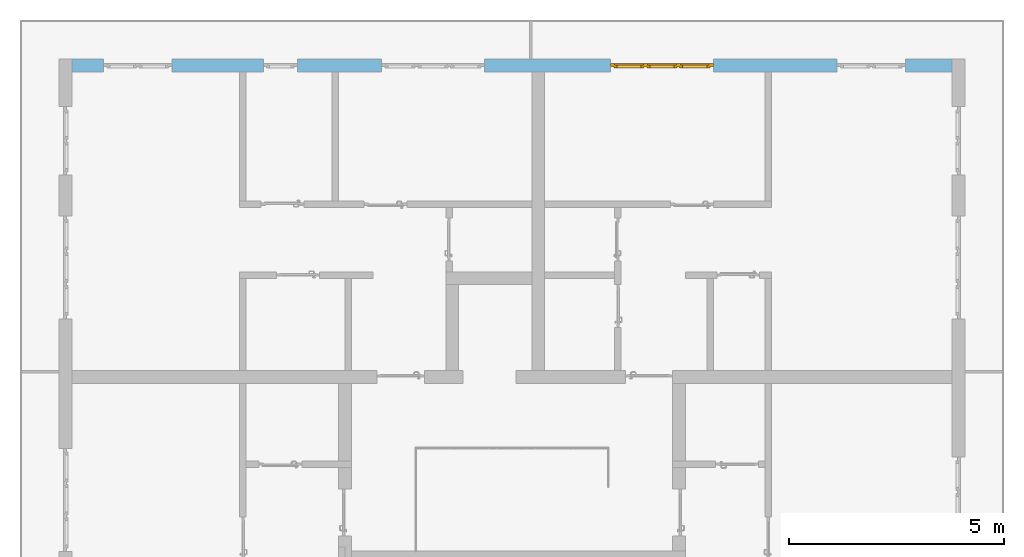
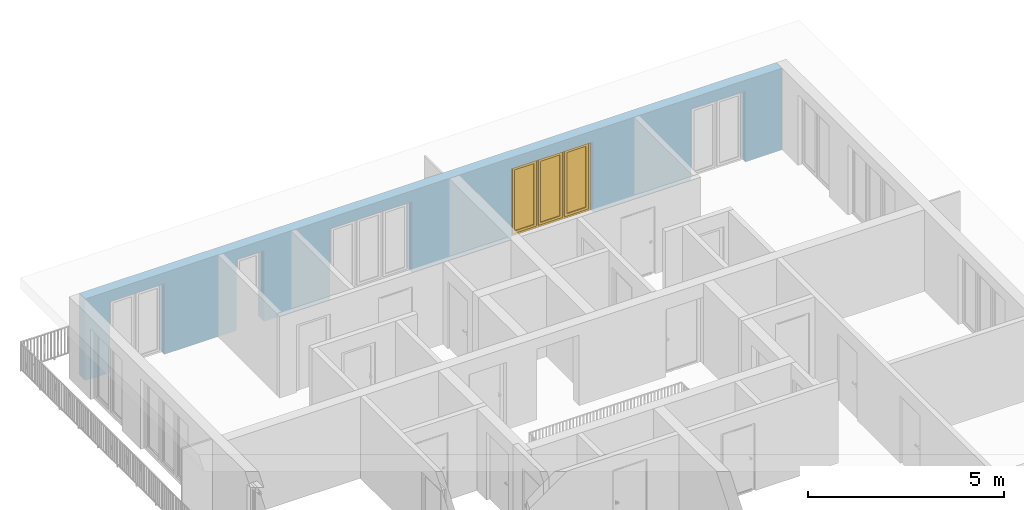
# One storey, part 29 of 54: 1 window, 5 openings, plus 1 element that does not belong to this part.
"""IFC4 building model written with IfcOpenShell, lengths in metres."""

from ifc_helpers import new_model, entity, si_unit, converted_unit, derived_unit, direction, frame, origin_with_axes, place, context, subcontext, project, spatial, polygons, source, transform, mapped, material, type_object, element, fill, save


model = new_model("IFC4")

# Units and contexts
model_context = context("Model", 3, precision=1e-05, world=origin_with_axes(), true_north=direction((0.0, 1.0)))
body_context = subcontext(model_context, "Body", "Model", "MODEL_VIEW")
ifc_project = project(units=[si_unit("LENGTHUNIT", "METRE"), si_unit("AREAUNIT", "SQUARE_METRE"), si_unit("VOLUMEUNIT", "CUBIC_METRE"), converted_unit("PLANEANGLEUNIT", "DEGREE", entity("IfcPlaneAngleMeasure", 0.0174532925199), si_unit("PLANEANGLEUNIT", "RADIAN"), dimensions=[0, 0, 0, 0, 0, 0, 0]), converted_unit("TIMEUNIT", "Year", entity("IfcTimeMeasure", 31556926.0), si_unit("TIMEUNIT", "SECOND"), dimensions=[0, 0, 1, 0, 0, 0, 0]), si_unit("MASSUNIT", "GRAM", prefix="KILO"), si_unit("THERMODYNAMICTEMPERATUREUNIT", "DEGREE_CELSIUS"), si_unit("LUMINOUSINTENSITYUNIT", "LUMEN"), si_unit("ENERGYUNIT", "JOULE", prefix="MEGA"), derived_unit("THERMALCONDUCTANCEUNIT", [(si_unit("POWERUNIT", "WATT"), 1), (si_unit("LENGTHUNIT", "METRE"), -1), (si_unit("THERMODYNAMICTEMPERATUREUNIT", "KELVIN"), -1)]), derived_unit("SPECIFICHEATCAPACITYUNIT", [(si_unit("ENERGYUNIT", "JOULE"), 1), (si_unit("MASSUNIT", "GRAM", prefix="KILO"), -1), (si_unit("THERMODYNAMICTEMPERATUREUNIT", "KELVIN"), -1)]), derived_unit("MASSDENSITYUNIT", [(si_unit("MASSUNIT", "GRAM", prefix="KILO"), 1), (si_unit("VOLUMEUNIT", "CUBIC_METRE"), -1)])], contexts=[model_context])

# Site, building, storey
site_placement = place(None, origin_with_axes())
site = spatial("IfcSite", under=ifc_project, at=site_placement, CompositionType="ELEMENT")
building_placement = place(site_placement, origin_with_axes())
building = spatial("IfcBuilding", under=site, at=building_placement, CompositionType="ELEMENT")
storey_placement = place(building_placement, frame((0.0, 0.0, 9.18), z_axis=(0.0, 0.0, 1.0), x_axis=(1.0, 0.0, 0.0)))
storey = spatial("IfcBuildingStorey", under=building, at=storey_placement, Name="3. Geschoss", CompositionType="ELEMENT", Elevation=9.18)

# Wall, openings, window
ifc_material = material()
wall_type = type_object("IfcWallType", Name="300", PredefinedType="NOTDEFINED")
wall_placement = place(storey_placement, frame((-11.7421993804, 8.92118776896, 0.0), z_axis=(0.0, 0.0, 1.0), x_axis=(1.0, 0.0, 0.0)))
wall = element("IfcWall", 1, at=wall_placement, inside=storey, type_object=wall_type, material=ifc_material, Name="Wand-001", PredefinedType="NOTDEFINED", context=body_context, shape_type="Tessellation", body=[
    polygons([(15.23, -0.1, 0.0), (15.23, -0.3, 0.0), (15.23, -0.3, 2.2), (15.23, 0.0, 2.2), (15.23, 0.0, 0.0), (18.102139809, 0.0, 0.0), (18.102139809, -0.3, 0.0), (18.102139809, -0.3, 2.2), (19.702139809, -0.3, 2.2), (19.702139809, -0.3, 0.0), (20.78, -0.3, 0.0), (20.78, -0.3, 2.54), (0.3, -0.3, 2.54), (0.3, -0.3, 0.0), (1.0288518641, -0.3, 0.0), (1.0288518641, -0.3, 2.2), (2.6288518641, -0.3, 2.2), (2.6288518641, -0.3, 0.0), (4.75, -0.3, 0.0), (4.75, -0.3, 2.2), (5.55, -0.3, 2.2), (5.55, -0.3, 0.0), (7.50089858046, -0.3, 0.0), (7.50089858046, -0.3, 2.2), (9.90089858046, -0.3, 2.2), (9.90089858046, -0.3, 0.0), (12.83, -0.3, 0.0), (12.83, -0.3, 2.2), (12.83, 0.0, 2.2), (12.83, 0.0, 0.0), (9.90089858046, 0.0, 0.0), (9.90089858046, 0.0, 2.2), (7.50089858046, 0.0, 2.2), (7.50089858046, 0.0, 0.0), (5.55, 0.0, 0.0), (5.55, 0.0, 2.2), (4.75, 0.0, 2.2), (4.75, 0.0, 0.0), (2.6288518641, 0.0, 0.0), (2.6288518641, 0.0, 2.2), (1.0288518641, 0.0, 2.2), (1.0288518641, 0.0, 0.0), (0.3, 0.0, 0.0), (0.3, 0.0, 2.54), (20.78, 0.0, 2.54), (20.78, 0.0, 0.0), (19.702139809, 0.0, 0.0), (19.702139809, 0.0, 2.2), (18.102139809, 0.0, 2.2), (12.83, -0.1, 0.0)], [[[1, 2, 3, 4, 5]], [[2, 1, 5, 6, 7]], [[3, 2, 7, 8, 9, 10, 11, 12, 13, 14, 15, 16, 17, 18, 19, 20, 21, 22, 23, 24, 25, 26, 27, 28]], [[4, 3, 28, 29]], [[6, 5, 4, 29, 30, 31, 32, 33, 34, 35, 36, 37, 38, 39, 40, 41, 42, 43, 44, 45, 46, 47, 48, 49]], [[6, 49, 8, 7]], [[8, 49, 48, 9]], [[48, 47, 10, 9]], [[46, 11, 10, 47]], [[12, 11, 46, 45]], [[45, 44, 13, 12]], [[44, 43, 14, 13]], [[15, 14, 43, 42]], [[16, 15, 42, 41]], [[40, 17, 16, 41]], [[18, 17, 40, 39]], [[19, 18, 39, 38]], [[20, 19, 38, 37]], [[36, 21, 20, 37]], [[22, 21, 36, 35]], [[22, 35, 34, 23]], [[34, 33, 24, 23]], [[24, 33, 32, 25]], [[32, 31, 26, 25]], [[50, 27, 26, 31, 30]], [[28, 27, 50, 30, 29]]], closed=True),
])
opening_1_placement = place(wall_placement, frame((1.8288518641, 0.0, 0.0), z_axis=(0.0, 0.0, 1.0), x_axis=(1.0, 0.0, 0.0)))
element("IfcOpeningElement", 2, at=opening_1_placement, cuts=wall, Name="Fenster-001", context=body_context, identifier="Reference", shape_type="Tessellation", body=[
    polygons([(-0.8, -0.1, 0.0), (-0.8, -0.1, 2.2), (-0.8, 0.000999999999998, 2.2), (-0.8, 0.000999999999998, 0.0), (-0.8, -0.301, 0.0), (-0.8, -0.301, 2.2), (0.8, -0.1, 2.2), (0.8, 0.000999999999999, 2.2), (0.8, -0.301, 2.2), (0.8, 0.000999999999999, 0.0), (0.8, -0.1, 0.0), (0.8, -0.301, 0.0)], [[[1, 2, 3, 4]], [[2, 1, 5, 6]], [[7, 8, 3, 2, 6, 9]], [[8, 10, 4, 3]], [[1, 4, 10, 11, 12, 5]], [[6, 5, 12, 9]], [[7, 11, 10, 8]], [[11, 7, 9, 12]]], closed=True),
])
opening_2_placement = place(wall_placement, frame((8.70089858046, 0.0, 0.0), z_axis=(0.0, 0.0, 1.0), x_axis=(1.0, 0.0, 0.0)))
element("IfcOpeningElement", 3, at=opening_2_placement, cuts=wall, Name="Fenster-002", context=body_context, identifier="Reference", shape_type="Tessellation", body=[
    polygons([(-1.2, -0.1, 0.0), (-1.2, -0.1, 2.2), (-1.2, 0.000999999999999, 2.2), (-1.2, 0.000999999999999, 0.0), (-1.2, -0.301, 0.0), (-1.2, -0.301, 2.2), (1.2, -0.1, 2.2), (1.2, 0.001, 2.2), (1.2, -0.301, 2.2), (1.2, 0.001, 0.0), (1.2, -0.1, 0.0), (1.2, -0.301, 0.0)], [[[1, 2, 3, 4]], [[2, 1, 5, 6]], [[7, 8, 3, 2, 6, 9]], [[8, 10, 4, 3]], [[1, 4, 10, 11, 12, 5]], [[6, 5, 12, 9]], [[7, 11, 10, 8]], [[11, 7, 9, 12]]], closed=True),
])
opening_3_placement = place(wall_placement, frame((5.15, 0.0, 0.0), z_axis=(0.0, 0.0, 1.0), x_axis=(1.0, 0.0, 0.0)))
element("IfcOpeningElement", 4, at=opening_3_placement, cuts=wall, Name="Fenster-003", context=body_context, identifier="Reference", shape_type="Tessellation", body=[
    polygons([(-0.4, -0.1, 0.0), (-0.4, -0.1, 2.2), (-0.4, 0.001, 2.2), (-0.4, 0.001, 0.0), (-0.4, -0.301, 0.0), (-0.4, -0.301, 2.2), (0.4, -0.1, 2.2), (0.4, 0.001, 2.2), (0.4, -0.301, 2.2), (0.4, 0.001, 0.0), (0.4, -0.1, 0.0), (0.4, -0.301, 0.0)], [[[1, 2, 3, 4]], [[2, 1, 5, 6]], [[7, 8, 3, 2, 6, 9]], [[8, 10, 4, 3]], [[1, 4, 10, 11, 12, 5]], [[6, 5, 12, 9]], [[7, 11, 10, 8]], [[11, 7, 9, 12]]], closed=True),
])
opening_4_placement = place(wall_placement, frame((18.902139809, 0.0, 0.0), z_axis=(0.0, 0.0, 1.0), x_axis=(1.0, 0.0, 0.0)))
element("IfcOpeningElement", 5, at=opening_4_placement, cuts=wall, Name="Fenster-001", context=body_context, identifier="Reference", shape_type="Tessellation", body=[
    polygons([(-0.8, -0.1, 0.0), (-0.8, -0.1, 2.2), (-0.8, 0.001, 2.2), (-0.8, 0.001, 0.0), (-0.8, -0.301, 0.0), (-0.8, -0.301, 2.2), (0.8, -0.1, 2.2), (0.8, 0.001, 2.2), (0.8, -0.301, 2.2), (0.8, 0.001, 0.0), (0.8, -0.1, 0.0), (0.8, -0.301, 0.0)], [[[1, 2, 3, 4]], [[2, 1, 5, 6]], [[7, 8, 3, 2, 6, 9]], [[8, 10, 4, 3]], [[1, 4, 10, 11, 12, 5]], [[6, 5, 12, 9]], [[7, 11, 10, 8]], [[11, 7, 9, 12]]], closed=True),
])
opening_5_placement = place(wall_placement, frame((14.03, 0.0, 0.0), z_axis=(0.0, 0.0, 1.0), x_axis=(1.0, 0.0, 0.0)))
opening_5 = element("IfcOpeningElement", 6, at=opening_5_placement, cuts=wall, Name="Fenster-002", context=body_context, identifier="Reference", shape_type="Tessellation", body=[
    polygons([(-1.2, -0.1, 0.0), (-1.2, -0.1, 2.2), (-1.2, 0.001, 2.2), (-1.2, 0.001, 0.0), (-1.2, -0.301, 0.0), (-1.2, -0.301, 2.2), (1.2, -0.1, 2.2), (1.2, 0.001, 2.2), (1.2, -0.301, 2.2), (1.2, 0.001, 0.0), (1.2, -0.1, 0.0), (1.2, -0.301, 0.0)], [[[1, 2, 3, 4]], [[2, 1, 5, 6]], [[7, 8, 3, 2, 6, 9]], [[8, 10, 4, 3]], [[1, 4, 10, 11, 12, 5]], [[6, 5, 12, 9]], [[7, 11, 10, 8]], [[11, 7, 9, 12]]], closed=True),
])
window_type = type_object("IfcWindowType", Name="3-1+1+1 26", PartitioningType="TRIPLE_PANEL_VERTICAL", PredefinedType="WINDOW")
shared_shape = source(origin_with_axes(), body_context, "Body", "Tessellation", [
    polygons([(-1.2, -0.07, 0.0), (-1.2, 0.0, 0.0), (-1.1, 0.0, 0.1), (-1.1, -0.07, 0.1), (-1.2, -0.07, 2.2), (-1.2, 0.0, 2.2), (-1.1, 0.0, 2.1), (-1.1, -0.07, 2.1)], [[[1, 2, 3, 4]], [[5, 6, 2, 1]], [[2, 6, 7, 3]], [[4, 3, 7, 8]], [[1, 4, 8, 5]], [[8, 7, 6, 5]]], closed=True),
    polygons([(1.2, -0.07, 0.0), (1.2, 0.0, 0.0), (1.2, 0.0, 2.2), (1.2, -0.07, 2.2), (1.1, -0.07, 0.1), (1.1, 0.0, 0.1), (1.1, 0.0, 2.1), (1.1, -0.07, 2.1)], [[[1, 2, 3, 4]], [[5, 6, 2, 1]], [[2, 6, 7, 3]], [[4, 3, 7, 8]], [[1, 4, 8, 5]], [[8, 7, 6, 5]]], closed=True),
    polygons([(-1.2, -0.07, 0.0), (-1.2, 0.0, 0.0), (1.2, 0.0, 0.0), (1.2, -0.07, 0.0), (-1.1, -0.07, 0.1), (-1.1, 0.0, 0.1), (-0.433333333333, 0.0, 0.1), (-0.333333333333, 0.0, 0.1), (0.333333333333, 0.0, 0.1), (0.433333333333, 0.0, 0.1), (1.1, 0.0, 0.1), (1.1, -0.07, 0.1), (0.433333333333, -0.07, 0.1), (0.333333333333, -0.07, 0.1), (-0.333333333333, -0.07, 0.1), (-0.433333333333, -0.07, 0.1)], [[[1, 2, 3, 4]], [[5, 6, 2, 1]], [[2, 6, 7, 8, 9, 10, 11, 3]], [[4, 3, 11, 12]], [[1, 4, 12, 13, 14, 15, 16, 5]], [[16, 7, 6, 5]], [[15, 8, 7, 16]], [[14, 9, 8, 15]], [[13, 10, 9, 14]], [[12, 11, 10, 13]]], closed=True),
    polygons([(-1.2, -0.07, 2.2), (-1.2, 0.0, 2.2), (-1.1, 0.0, 2.1), (-1.1, -0.07, 2.1), (1.2, -0.07, 2.2), (1.2, 0.0, 2.2), (1.1, 0.0, 2.1), (0.433333333333, 0.0, 2.1), (0.333333333333, 0.0, 2.1), (-0.333333333333, 0.0, 2.1), (-0.433333333333, 0.0, 2.1), (-0.433333333333, -0.07, 2.1), (-0.333333333333, -0.07, 2.1), (0.333333333333, -0.07, 2.1), (0.433333333333, -0.07, 2.1), (1.1, -0.07, 2.1)], [[[1, 2, 3, 4]], [[5, 6, 2, 1]], [[2, 6, 7, 8, 9, 10, 11, 3]], [[4, 3, 11, 12]], [[1, 4, 12, 13, 14, 15, 16, 5]], [[16, 7, 6, 5]], [[15, 8, 7, 16]], [[14, 9, 8, 15]], [[13, 10, 9, 14]], [[12, 11, 10, 13]]], closed=True),
    polygons([(0.333333333333, -0.07, 0.1), (0.333333333333, 0.0, 0.1), (0.433333333333, 0.0, 0.1), (0.433333333333, -0.07, 0.1), (0.333333333333, -0.07, 2.1), (0.333333333333, 0.0, 2.1), (0.433333333333, 0.0, 2.1), (0.433333333333, -0.07, 2.1)], [[[1, 2, 3, 4]], [[5, 6, 2, 1]], [[2, 6, 7, 3]], [[4, 3, 7, 8]], [[1, 4, 8, 5]], [[8, 7, 6, 5]]], closed=True),
    polygons([(-0.433333333333, -0.07, 0.1), (-0.433333333333, 0.0, 0.1), (-0.333333333333, 0.0, 0.1), (-0.333333333333, -0.07, 0.1), (-0.433333333333, -0.07, 2.1), (-0.433333333333, 0.0, 2.1), (-0.333333333333, 0.0, 2.1), (-0.333333333333, -0.07, 2.1)], [[[1, 2, 3, 4]], [[5, 6, 2, 1]], [[2, 6, 7, 3]], [[4, 3, 7, 8]], [[1, 4, 8, 5]], [[8, 7, 6, 5]]], closed=True),
    polygons([(-1.12, 0.0, 0.08), (-1.12, 0.03, 0.08), (-1.05, 0.03, 0.15), (-1.05, 0.0, 0.15), (-1.12, 0.0, 2.12), (-1.12, 0.03, 2.12), (-1.05, 0.03, 2.05), (-1.05, 0.0, 2.05)], [[[1, 2, 3, 4]], [[5, 6, 2, 1]], [[2, 6, 7, 3]], [[4, 3, 7, 8]], [[1, 4, 8, 5]], [[8, 7, 6, 5]]], closed=True),
    polygons([(-0.413333333333, 0.0, 0.08), (-0.483333333333, 0.0, 0.15), (-0.483333333333, 0.03, 0.15), (-0.413333333333, 0.03, 0.08), (-0.413333333333, 0.0, 2.12), (-0.483333333333, 0.0, 2.05), (-0.483333333333, 0.03, 2.05), (-0.413333333333, 0.03, 2.12)], [[[1, 2, 3, 4]], [[1, 5, 6, 2]], [[2, 6, 7, 3]], [[4, 3, 7, 8]], [[5, 1, 4, 8]], [[6, 5, 8, 7]]], closed=True),
    polygons([(-1.12, 0.0, 0.08), (-1.12, 0.03, 0.08), (-0.413333333333, 0.03, 0.08), (-0.413333333333, 0.0, 0.08), (-1.05, 0.0, 0.15), (-1.05, 0.03, 0.15), (-0.483333333333, 0.03, 0.15), (-0.483333333333, 0.0, 0.15)], [[[1, 2, 3, 4]], [[5, 6, 2, 1]], [[2, 6, 7, 3]], [[4, 3, 7, 8]], [[1, 4, 8, 5]], [[8, 7, 6, 5]]], closed=True),
    polygons([(-1.12, 0.0, 2.12), (-0.413333333333, 0.0, 2.12), (-0.413333333333, 0.03, 2.12), (-1.12, 0.03, 2.12), (-1.05, 0.0, 2.05), (-0.483333333333, 0.0, 2.05), (-0.483333333333, 0.03, 2.05), (-1.05, 0.03, 2.05)], [[[1, 2, 3, 4]], [[1, 5, 6, 2]], [[2, 6, 7, 3]], [[4, 3, 7, 8]], [[5, 1, 4, 8]], [[6, 5, 8, 7]]], closed=True),
    polygons([(-1.1, -0.03, 0.1), (-1.1, 0.0, 0.1), (-1.05, 0.0, 0.15), (-1.05, -0.03, 0.15), (-1.1, -0.03, 2.1), (-1.1, 0.0, 2.1), (-1.05, 0.0, 2.05), (-1.05, -0.03, 2.05)], [[[1, 2, 3, 4]], [[5, 6, 2, 1]], [[2, 6, 7, 3]], [[4, 3, 7, 8]], [[1, 4, 8, 5]], [[8, 7, 6, 5]]], closed=True),
    polygons([(-0.433333333333, -0.03, 0.1), (-0.483333333333, -0.03, 0.15), (-0.483333333333, 0.0, 0.15), (-0.433333333333, 0.0, 0.1), (-0.433333333333, -0.03, 2.1), (-0.483333333333, -0.03, 2.05), (-0.483333333333, 0.0, 2.05), (-0.433333333333, 0.0, 2.1)], [[[1, 2, 3, 4]], [[1, 5, 6, 2]], [[2, 6, 7, 3]], [[4, 3, 7, 8]], [[5, 1, 4, 8]], [[6, 5, 8, 7]]], closed=True),
    polygons([(-1.1, -0.03, 0.1), (-1.1, 0.0, 0.1), (-0.433333333333, 0.0, 0.1), (-0.433333333333, -0.03, 0.1), (-1.05, -0.03, 0.15), (-1.05, 0.0, 0.15), (-0.483333333333, 0.0, 0.15), (-0.483333333333, -0.03, 0.15)], [[[1, 2, 3, 4]], [[5, 6, 2, 1]], [[2, 6, 7, 3]], [[4, 3, 7, 8]], [[1, 4, 8, 5]], [[8, 7, 6, 5]]], closed=True),
    polygons([(-1.1, -0.03, 2.1), (-0.433333333333, -0.03, 2.1), (-0.433333333333, 0.0, 2.1), (-1.1, 0.0, 2.1), (-1.05, -0.03, 2.05), (-0.483333333333, -0.03, 2.05), (-0.483333333333, 0.0, 2.05), (-1.05, 0.0, 2.05)], [[[1, 2, 3, 4]], [[1, 5, 6, 2]], [[2, 6, 7, 3]], [[4, 3, 7, 8]], [[5, 1, 4, 8]], [[6, 5, 8, 7]]], closed=True),
    polygons([(-1.05, -0.005, 0.15), (-1.05, 0.005, 0.15), (-0.483333333333, 0.005, 0.15), (-0.483333333333, -0.005, 0.15), (-1.05, -0.005, 2.05), (-1.05, 0.005, 2.05), (-0.483333333333, 0.005, 2.05), (-0.483333333333, -0.005, 2.05)], [[[1, 2, 3, 4]], [[5, 6, 2, 1]], [[2, 6, 7, 3]], [[4, 3, 7, 8]], [[1, 4, 8, 5]], [[8, 7, 6, 5]]], closed=True),
    polygons([(-0.353333333333, 0.0, 0.08), (-0.353333333333, 0.03, 0.08), (-0.283333333333, 0.03, 0.15), (-0.283333333333, 0.0, 0.15), (-0.353333333333, 0.0, 2.12), (-0.353333333333, 0.03, 2.12), (-0.283333333333, 0.03, 2.05), (-0.283333333333, 0.0, 2.05)], [[[1, 2, 3, 4]], [[5, 6, 2, 1]], [[2, 6, 7, 3]], [[4, 3, 7, 8]], [[1, 4, 8, 5]], [[8, 7, 6, 5]]], closed=True),
    polygons([(0.353333333333, 0.0, 0.08), (0.283333333333, 0.0, 0.15), (0.283333333333, 0.03, 0.15), (0.353333333333, 0.03, 0.08), (0.353333333333, 0.0, 2.12), (0.283333333333, 0.0, 2.05), (0.283333333333, 0.03, 2.05), (0.353333333333, 0.03, 2.12)], [[[1, 2, 3, 4]], [[1, 5, 6, 2]], [[2, 6, 7, 3]], [[4, 3, 7, 8]], [[5, 1, 4, 8]], [[6, 5, 8, 7]]], closed=True),
    polygons([(-0.353333333333, 0.0, 0.08), (-0.353333333333, 0.03, 0.08), (0.353333333333, 0.03, 0.08), (0.353333333333, 0.0, 0.08), (-0.283333333333, 0.0, 0.15), (-0.283333333333, 0.03, 0.15), (0.283333333333, 0.03, 0.15), (0.283333333333, 0.0, 0.15)], [[[1, 2, 3, 4]], [[5, 6, 2, 1]], [[2, 6, 7, 3]], [[4, 3, 7, 8]], [[1, 4, 8, 5]], [[8, 7, 6, 5]]], closed=True),
    polygons([(-0.353333333333, 0.0, 2.12), (0.353333333333, 0.0, 2.12), (0.353333333333, 0.03, 2.12), (-0.353333333333, 0.03, 2.12), (-0.283333333333, 0.0, 2.05), (0.283333333333, 0.0, 2.05), (0.283333333333, 0.03, 2.05), (-0.283333333333, 0.03, 2.05)], [[[1, 2, 3, 4]], [[1, 5, 6, 2]], [[2, 6, 7, 3]], [[4, 3, 7, 8]], [[5, 1, 4, 8]], [[6, 5, 8, 7]]], closed=True),
    polygons([(-0.333333333333, -0.03, 0.1), (-0.333333333333, 0.0, 0.1), (-0.283333333333, 0.0, 0.15), (-0.283333333333, -0.03, 0.15), (-0.333333333333, -0.03, 2.1), (-0.333333333333, 0.0, 2.1), (-0.283333333333, 0.0, 2.05), (-0.283333333333, -0.03, 2.05)], [[[1, 2, 3, 4]], [[5, 6, 2, 1]], [[2, 6, 7, 3]], [[4, 3, 7, 8]], [[1, 4, 8, 5]], [[8, 7, 6, 5]]], closed=True),
    polygons([(0.333333333333, -0.03, 0.1), (0.283333333333, -0.03, 0.15), (0.283333333333, 0.0, 0.15), (0.333333333333, 0.0, 0.1), (0.333333333333, -0.03, 2.1), (0.283333333333, -0.03, 2.05), (0.283333333333, 0.0, 2.05), (0.333333333333, 0.0, 2.1)], [[[1, 2, 3, 4]], [[1, 5, 6, 2]], [[2, 6, 7, 3]], [[4, 3, 7, 8]], [[5, 1, 4, 8]], [[6, 5, 8, 7]]], closed=True),
    polygons([(-0.333333333333, -0.03, 0.1), (-0.333333333333, 0.0, 0.1), (0.333333333333, 0.0, 0.1), (0.333333333333, -0.03, 0.1), (-0.283333333333, -0.03, 0.15), (-0.283333333333, 0.0, 0.15), (0.283333333333, 0.0, 0.15), (0.283333333333, -0.03, 0.15)], [[[1, 2, 3, 4]], [[5, 6, 2, 1]], [[2, 6, 7, 3]], [[4, 3, 7, 8]], [[1, 4, 8, 5]], [[8, 7, 6, 5]]], closed=True),
    polygons([(-0.333333333333, -0.03, 2.1), (0.333333333333, -0.03, 2.1), (0.333333333333, 0.0, 2.1), (-0.333333333333, 0.0, 2.1), (-0.283333333333, -0.03, 2.05), (0.283333333333, -0.03, 2.05), (0.283333333333, 0.0, 2.05), (-0.283333333333, 0.0, 2.05)], [[[1, 2, 3, 4]], [[1, 5, 6, 2]], [[2, 6, 7, 3]], [[4, 3, 7, 8]], [[5, 1, 4, 8]], [[6, 5, 8, 7]]], closed=True),
    polygons([(-0.283333333333, -0.005, 0.15), (-0.283333333333, 0.005, 0.15), (0.283333333333, 0.005, 0.15), (0.283333333333, -0.005, 0.15), (-0.283333333333, -0.005, 2.05), (-0.283333333333, 0.005, 2.05), (0.283333333333, 0.005, 2.05), (0.283333333333, -0.005, 2.05)], [[[1, 2, 3, 4]], [[5, 6, 2, 1]], [[2, 6, 7, 3]], [[4, 3, 7, 8]], [[1, 4, 8, 5]], [[8, 7, 6, 5]]], closed=True),
    polygons([(0.413333333333, 0.0, 0.08), (0.413333333333, 0.03, 0.08), (0.483333333333, 0.03, 0.15), (0.483333333333, 0.0, 0.15), (0.413333333333, 0.0, 2.12), (0.413333333333, 0.03, 2.12), (0.483333333333, 0.03, 2.05), (0.483333333333, 0.0, 2.05)], [[[1, 2, 3, 4]], [[5, 6, 2, 1]], [[2, 6, 7, 3]], [[4, 3, 7, 8]], [[1, 4, 8, 5]], [[8, 7, 6, 5]]], closed=True),
    polygons([(1.12, 0.0, 0.08), (1.05, 0.0, 0.15), (1.05, 0.03, 0.15), (1.12, 0.03, 0.08), (1.12, 0.0, 2.12), (1.05, 0.0, 2.05), (1.05, 0.03, 2.05), (1.12, 0.03, 2.12)], [[[1, 2, 3, 4]], [[1, 5, 6, 2]], [[2, 6, 7, 3]], [[4, 3, 7, 8]], [[5, 1, 4, 8]], [[6, 5, 8, 7]]], closed=True),
    polygons([(0.413333333333, 0.0, 0.08), (0.413333333333, 0.03, 0.08), (1.12, 0.03, 0.08), (1.12, 0.0, 0.08), (0.483333333333, 0.0, 0.15), (0.483333333333, 0.03, 0.15), (1.05, 0.03, 0.15), (1.05, 0.0, 0.15)], [[[1, 2, 3, 4]], [[5, 6, 2, 1]], [[2, 6, 7, 3]], [[4, 3, 7, 8]], [[1, 4, 8, 5]], [[8, 7, 6, 5]]], closed=True),
    polygons([(0.413333333333, 0.0, 2.12), (1.12, 0.0, 2.12), (1.12, 0.03, 2.12), (0.413333333333, 0.03, 2.12), (0.483333333333, 0.0, 2.05), (1.05, 0.0, 2.05), (1.05, 0.03, 2.05), (0.483333333333, 0.03, 2.05)], [[[1, 2, 3, 4]], [[1, 5, 6, 2]], [[2, 6, 7, 3]], [[4, 3, 7, 8]], [[5, 1, 4, 8]], [[6, 5, 8, 7]]], closed=True),
    polygons([(0.433333333333, -0.03, 0.1), (0.433333333333, 0.0, 0.1), (0.483333333333, 0.0, 0.15), (0.483333333333, -0.03, 0.15), (0.433333333333, -0.03, 2.1), (0.433333333333, 0.0, 2.1), (0.483333333333, 0.0, 2.05), (0.483333333333, -0.03, 2.05)], [[[1, 2, 3, 4]], [[5, 6, 2, 1]], [[2, 6, 7, 3]], [[4, 3, 7, 8]], [[1, 4, 8, 5]], [[8, 7, 6, 5]]], closed=True),
    polygons([(1.1, -0.03, 0.1), (1.05, -0.03, 0.15), (1.05, 0.0, 0.15), (1.1, 0.0, 0.1), (1.1, -0.03, 2.1), (1.05, -0.03, 2.05), (1.05, 0.0, 2.05), (1.1, 0.0, 2.1)], [[[1, 2, 3, 4]], [[1, 5, 6, 2]], [[2, 6, 7, 3]], [[4, 3, 7, 8]], [[5, 1, 4, 8]], [[6, 5, 8, 7]]], closed=True),
    polygons([(0.433333333333, -0.03, 0.1), (0.433333333333, 0.0, 0.1), (1.1, 0.0, 0.1), (1.1, -0.03, 0.1), (0.483333333333, -0.03, 0.15), (0.483333333333, 0.0, 0.15), (1.05, 0.0, 0.15), (1.05, -0.03, 0.15)], [[[1, 2, 3, 4]], [[5, 6, 2, 1]], [[2, 6, 7, 3]], [[4, 3, 7, 8]], [[1, 4, 8, 5]], [[8, 7, 6, 5]]], closed=True),
    polygons([(0.433333333333, -0.03, 2.1), (1.1, -0.03, 2.1), (1.1, 0.0, 2.1), (0.433333333333, 0.0, 2.1), (0.483333333333, -0.03, 2.05), (1.05, -0.03, 2.05), (1.05, 0.0, 2.05), (0.483333333333, 0.0, 2.05)], [[[1, 2, 3, 4]], [[1, 5, 6, 2]], [[2, 6, 7, 3]], [[4, 3, 7, 8]], [[5, 1, 4, 8]], [[6, 5, 8, 7]]], closed=True),
    polygons([(0.483333333333, -0.005, 0.15), (0.483333333333, 0.005, 0.15), (1.05, 0.005, 0.15), (1.05, -0.005, 0.15), (0.483333333333, -0.005, 2.05), (0.483333333333, 0.005, 2.05), (1.05, 0.005, 2.05), (1.05, -0.005, 2.05)], [[[1, 2, 3, 4]], [[5, 6, 2, 1]], [[2, 6, 7, 3]], [[4, 3, 7, 8]], [[1, 4, 8, 5]], [[8, 7, 6, 5]]], closed=True),
])
window_placement = place(opening_5_placement, frame((1.2, 0.0, 0.0), z_axis=(0.0, 0.0, 1.0), x_axis=(-1.0, 0.0, 0.0)))
window = element("IfcWindow", 7, at=window_placement, inside=storey, type_object=window_type, Name="Fenster-002", OverallHeight=2.2, OverallWidth=2.4, PredefinedType="WINDOW", context=body_context, shape_type="MappedRepresentation", body=[
    mapped(shared_shape, transform((1.2, 0.17, 0.0))),
])
fill(opening_5, window)

save(model, "model.ifc")
